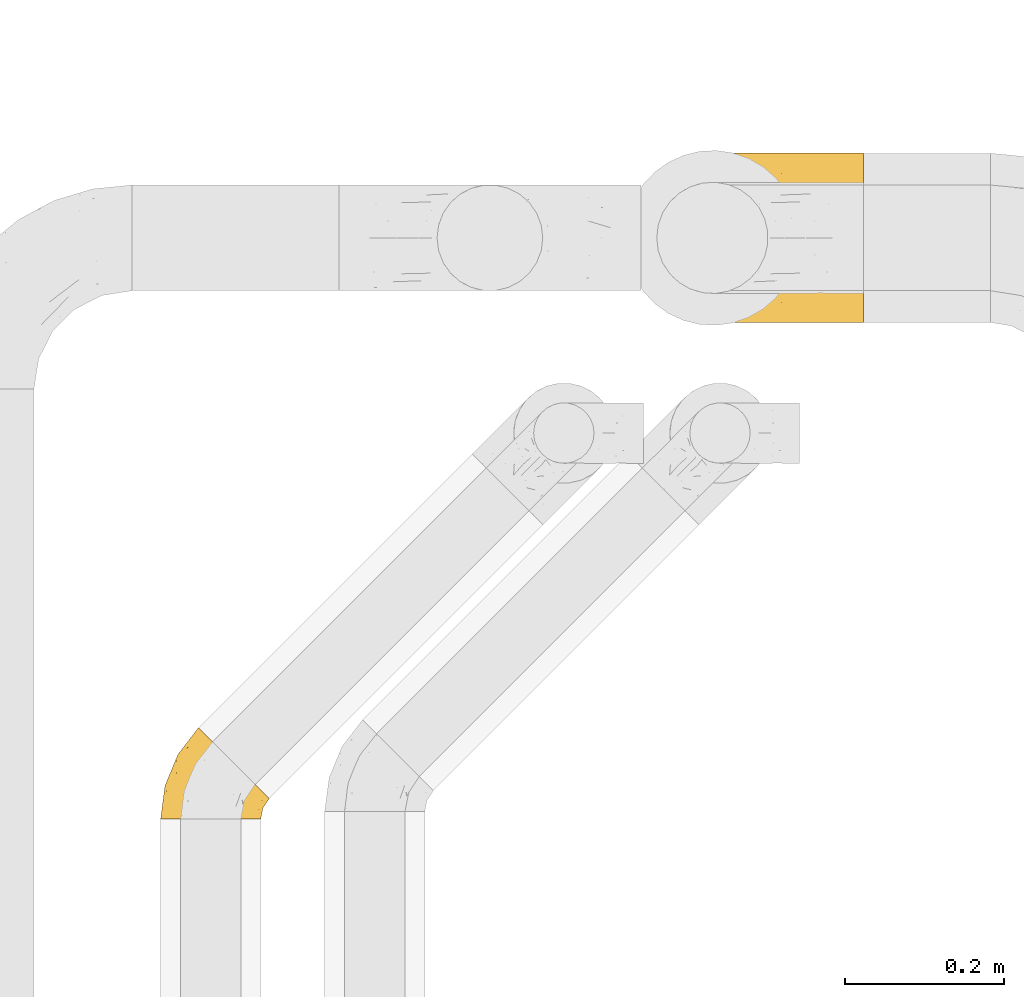
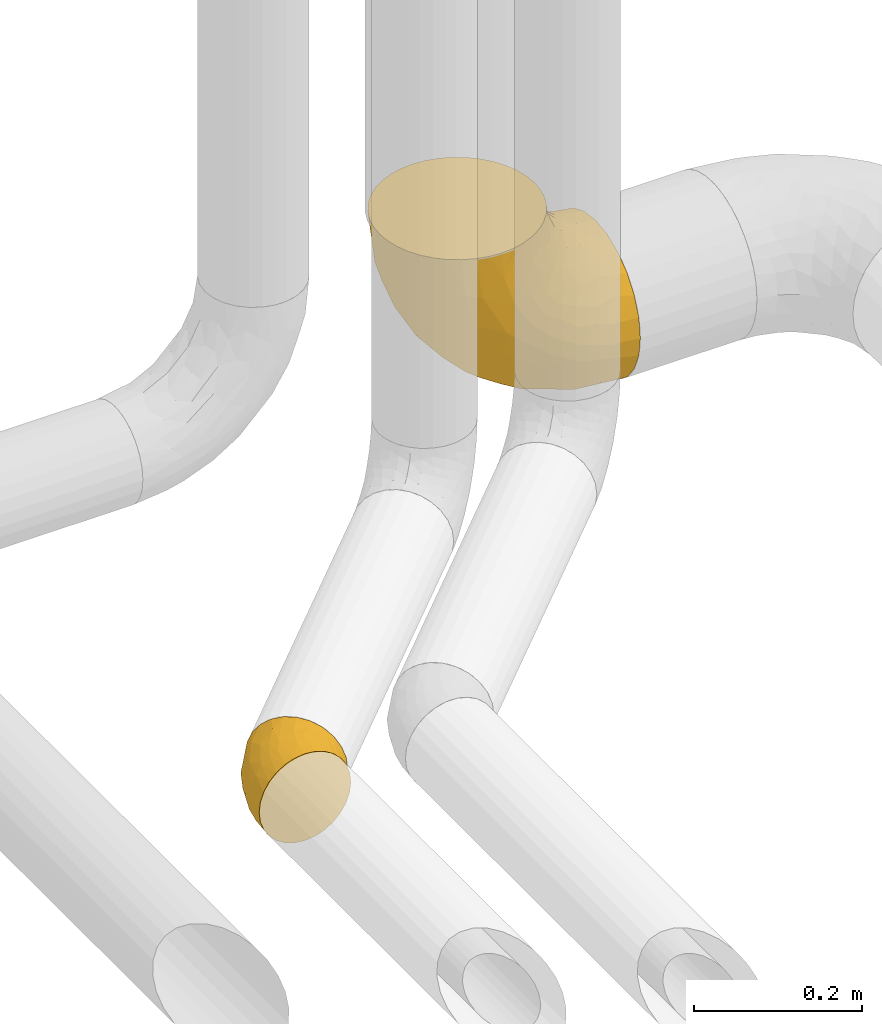
# One storey, part 34 of 93: 2 coverings.
"""IFC2X3 building model written with IfcOpenShell, lengths in millimetres."""

from ifc_helpers import new_model, entity, si_unit, converted_unit, derived_unit, direction, frame, origin, place, context, subcontext, project, spatial, faceted_brep, element, save


model = new_model("IFC2X3")

# Units and contexts
model_context = context("Model", 3, precision=0.01, world=origin(), true_north=direction((6.12303176911189e-17, 1.0)))
body_context = subcontext(model_context, "Body", "Model", "MODEL_VIEW")
ifc_project = project(units=[si_unit("LENGTHUNIT", "METRE", prefix="MILLI"), si_unit("AREAUNIT", "SQUARE_METRE"), si_unit("VOLUMEUNIT", "CUBIC_METRE"), converted_unit("PLANEANGLEUNIT", "DEGREE", entity("IfcRatioMeasure", 0.0174532925199433), si_unit("PLANEANGLEUNIT", "RADIAN"), dimensions=[0, 0, 0, 0, 0, 0, 0]), si_unit("MASSUNIT", "GRAM", prefix="KILO"), derived_unit("MASSDENSITYUNIT", [(si_unit("MASSUNIT", "GRAM", prefix="KILO"), 1), (si_unit("LENGTHUNIT", "METRE"), -3)]), derived_unit("MOMENTOFINERTIAUNIT", [(si_unit("LENGTHUNIT", "METRE"), 4)]), si_unit("TIMEUNIT", "SECOND"), si_unit("FREQUENCYUNIT", "HERTZ"), si_unit("THERMODYNAMICTEMPERATUREUNIT", "DEGREE_CELSIUS"), derived_unit("THERMALTRANSMITTANCEUNIT", [(si_unit("MASSUNIT", "GRAM", prefix="KILO"), 1), (si_unit("THERMODYNAMICTEMPERATUREUNIT", "KELVIN"), -1), (si_unit("TIMEUNIT", "SECOND"), -3)]), derived_unit("VOLUMETRICFLOWRATEUNIT", [(si_unit("LENGTHUNIT", "METRE"), 3), (si_unit("TIMEUNIT", "SECOND"), -1)]), derived_unit("MASSFLOWRATEUNIT", [(si_unit("MASSUNIT", "GRAM", prefix="KILO"), 1), (si_unit("TIMEUNIT", "SECOND"), -1)]), derived_unit("ROTATIONALFREQUENCYUNIT", [(si_unit("TIMEUNIT", "SECOND"), -1)]), si_unit("ELECTRICCURRENTUNIT", "AMPERE"), si_unit("ELECTRICVOLTAGEUNIT", "VOLT"), si_unit("POWERUNIT", "WATT"), si_unit("FORCEUNIT", "NEWTON", prefix="KILO"), si_unit("ILLUMINANCEUNIT", "LUX"), si_unit("LUMINOUSFLUXUNIT", "LUMEN"), si_unit("LUMINOUSINTENSITYUNIT", "CANDELA"), derived_unit("USERDEFINED", [(si_unit("MASSUNIT", "GRAM", prefix="KILO"), -1), (si_unit("LENGTHUNIT", "METRE"), -2), (si_unit("TIMEUNIT", "SECOND"), 3), (si_unit("LUMINOUSFLUXUNIT", "LUMEN"), 1)]), derived_unit("LINEARVELOCITYUNIT", [(si_unit("LENGTHUNIT", "METRE"), 1), (si_unit("TIMEUNIT", "SECOND"), -1)]), si_unit("PRESSUREUNIT", "PASCAL"), derived_unit("USERDEFINED", [(si_unit("LENGTHUNIT", "METRE"), -2), (si_unit("MASSUNIT", "GRAM", prefix="KILO"), 1), (si_unit("TIMEUNIT", "SECOND"), -2)]), derived_unit("LINEARFORCEUNIT", [(si_unit("MASSUNIT", "GRAM", prefix="KILO"), 1), (si_unit("LENGTHUNIT", "METRE"), 1), (si_unit("TIMEUNIT", "SECOND"), -2), (si_unit("LENGTHUNIT", "METRE"), -1)]), derived_unit("PLANARFORCEUNIT", [(si_unit("MASSUNIT", "GRAM", prefix="KILO"), 1), (si_unit("LENGTHUNIT", "METRE"), 1), (si_unit("TIMEUNIT", "SECOND"), -2), (si_unit("LENGTHUNIT", "METRE"), -2)])], contexts=[model_context])

# Site, building, storey
site_placement = place(None, origin())
site = spatial("IfcSite", under=ifc_project, at=site_placement, CompositionType="ELEMENT")
building_placement = place(site_placement, origin())
building = spatial("IfcBuilding", under=site, at=building_placement, CompositionType="ELEMENT")
storey_placement = place(building_placement, frame((0.0, 0.0, -4200.0)))
storey = spatial("IfcBuildingStorey", under=building, at=storey_placement, CompositionType="ELEMENT", Elevation=-4200.0)

# Coverings
covering_1_placement = place(storey_placement, frame((24991.03, 12207.47, 2891.9)))
element("IfcCovering", 1, at=covering_1_placement, inside=storey, Name=":ADSK_", ObjectType=":ADSK_", PredefinedType="INSULATION", context=body_context, shape_type="Brep", body=[
    faceted_brep([(59.74, 202.99, 298.1), (45.49, 194.25, 298.1), (32.79, 183.4, 298.1), (21.93, 170.69, 298.1), (13.2, 156.45, 298.1), (6.81, 141.01, 298.1), (2.91, 124.76, 298.1), (1.6, 108.1, 298.1), (2.91, 91.43, 298.1), (6.81, 75.18, 298.1), (13.21, 59.74, 298.1), (21.94, 45.49, 298.1), (32.79, 32.79, 298.1), (45.5, 21.93, 298.1), (59.74, 13.2, 298.1), (75.18, 6.81, 298.1), (91.43, 2.91, 298.1), (108.1, 1.6, 298.1), (124.76, 2.91, 298.1), (141.01, 6.81, 298.1), (156.45, 13.21, 298.1), (170.7, 21.94, 298.1), (183.4, 32.79, 298.1), (194.26, 45.5, 298.1), (202.99, 59.74, 298.1), (209.38, 75.18, 298.1), (213.28, 91.43, 298.1), (214.6, 108.1, 298.1), (213.28, 124.76, 298.1), (209.38, 141.01, 298.1), (202.99, 156.45, 298.1), (194.25, 170.7, 298.1), (183.4, 183.4, 298.1), (170.69, 194.26, 298.1), (156.45, 202.99, 298.1), (141.01, 209.38, 298.1), (124.76, 213.28, 298.1), (108.1, 214.6, 298.1), (91.43, 213.28, 298.1), (75.18, 209.38, 298.1), (298.1, 108.1, 214.6), (298.1, 80.53, 210.97), (298.1, 54.85, 200.33), (298.1, 32.79, 183.4), (298.1, 15.86, 161.35), (298.1, 5.22, 135.66), (298.1, 4.13, 127.32), (298.1, 1.6, 108.1), (298.1, 5.22, 80.53), (298.1, 15.86, 54.85), (298.1, 32.79, 32.79), (298.1, 54.85, 15.86), (298.1, 80.53, 5.22), (298.1, 108.1, 1.6), (298.1, 135.66, 5.22), (298.1, 161.35, 15.86), (298.1, 183.4, 32.79), (298.1, 200.33, 54.85), (298.1, 210.97, 80.53), (298.1, 214.6, 108.1), (298.1, 212.06, 127.32), (298.1, 210.97, 135.66), (298.1, 200.33, 161.35), (298.1, 183.4, 183.4), (298.1, 161.35, 200.33), (298.1, 135.66, 210.97), (215.9, 136.66, 17.28), (240.25, 108.1, 7.29), (184.63, 108.1, 24.16), (173.62, 212.57, 128.12), (149.55, 214.6, 179.63), (164.59, 214.6, 164.59), (179.63, 214.6, 149.55), (15.37, 125.87, 213.86), (115.17, 147.8, 74.58), (108.31, 127.1, 72.52), (71.9, 138.36, 113.27), (80.69, 201.53, 193.84), (116.68, 201.95, 140.45), (70.43, 181.04, 157.45), (133.37, 108.1, 51.56), (88.44, 108.1, 88.44), (84.59, 209.78, 238.51), (256.47, 190.34, 43.82), (152.12, 132.23, 43.2), (42.47, 157.12, 173.1), (38.05, 134.47, 162.69), (51.56, 108.1, 133.37), (217.02, 212.01, 100.8), (255.82, 214.6, 112.86), (271.69, 214.6, 111.07), (221.39, 203.11, 72.67), (167.38, 206.52, 108.04), (112.86, 214.6, 255.82), (203.39, 187.2, 54.55), (232.94, 169.39, 28.77), (154.06, 185.33, 77.65), (144.28, 196.93, 102.61), (64.22, 202.17, 244.56), (16.68, 145.9, 229.88), (28.56, 167.06, 227.28), (117.19, 210.85, 176.45), (215.66, 214.6, 126.91), (126.91, 214.6, 215.66), (138.23, 214.6, 197.64), (46.68, 184.43, 216.69), (130.52, 169.67, 77.66), (83.03, 164.53, 118.3), (175.16, 173.37, 53.05), (167.12, 155.91, 44.79), (7.29, 108.1, 240.25), (235.74, 214.6, 119.89), (119.89, 214.6, 235.74), (24.16, 108.1, 184.63), (111.07, 214.6, 271.69), (111.97, 185.43, 111.97), (197.64, 214.6, 138.23), (152.84, 212.34, 213.28), (155.48, 205.66, 261.27), (172.59, 202.01, 236.57), (264.78, 211.0, 138.98), (243.36, 171.72, 208.96), (229.26, 159.74, 229.94), (254.06, 147.87, 218.23), (240.21, 210.94, 146.43), (273.24, 198.07, 167.43), (216.52, 183.74, 216.99), (231.35, 190.37, 195.52), (199.76, 172.23, 261.35), (206.05, 155.44, 276.24), (215.74, 204.99, 177.77), (212.96, 212.5, 152.11), (194.42, 211.92, 168.08), (241.64, 203.94, 166.1), (236.85, 133.68, 236.85), (259.64, 182.45, 191.04), (270.63, 161.19, 204.36), (218.68, 108.1, 272.29), (214.32, 137.48, 272.37), (258.6, 126.56, 222.7), (275.05, 137.38, 213.58), (138.58, 212.54, 241.75), (140.53, 210.23, 271.32), (172.52, 194.59, 274.0), (186.21, 185.51, 264.36), (249.02, 108.1, 230.54), (230.54, 108.1, 249.02), (272.29, 108.1, 218.68), (207.91, 174.93, 240.35), (194.73, 189.35, 234.91), (222.52, 141.01, 251.63), (212.36, 158.65, 254.32), (174.06, 207.65, 209.93), (208.29, 197.48, 201.23), (170.15, 212.79, 185.4), (190.86, 207.45, 190.86), (236.85, 82.51, 236.85), (199.76, 43.96, 261.35), (212.36, 57.54, 254.32), (206.05, 60.75, 276.24), (275.05, 78.82, 213.58), (258.6, 89.63, 222.7), (241.64, 12.25, 166.1), (273.24, 18.12, 167.43), (259.64, 33.74, 191.04), (194.73, 26.85, 234.91), (174.06, 8.54, 209.94), (208.28, 18.72, 201.24), (254.06, 68.32, 218.23), (140.54, 5.96, 271.31), (119.89, 1.6, 235.74), (138.59, 3.65, 241.75), (270.58, 54.56, 204.11), (255.82, 1.6, 112.86), (271.69, 1.6, 111.07), (155.48, 10.53, 261.27), (172.52, 21.6, 274.0), (264.78, 5.19, 138.98), (243.36, 44.47, 208.96), (212.94, 3.69, 152.11), (240.19, 5.25, 146.42), (164.59, 1.6, 164.59), (179.63, 1.6, 149.55), (194.44, 4.27, 168.09), (229.26, 56.45, 229.94), (214.32, 78.71, 272.37), (215.75, 11.2, 177.78), (231.35, 25.82, 195.52), (216.52, 32.45, 216.99), (222.52, 75.19, 251.64), (111.07, 1.6, 271.69), (186.21, 30.69, 264.36), (126.91, 1.6, 215.66), (152.84, 3.85, 213.27), (170.15, 3.4, 185.4), (207.92, 41.26, 240.36), (172.6, 14.19, 236.58), (112.86, 1.6, 255.82), (138.23, 1.6, 197.64), (149.55, 1.6, 179.63), (190.86, 8.74, 190.86), (235.74, 1.6, 119.89), (197.64, 1.6, 138.23), (215.66, 1.6, 126.91), (217.02, 4.18, 100.8), (173.62, 3.62, 128.12), (167.38, 9.67, 108.04), (256.48, 25.85, 43.82), (221.39, 13.08, 72.67), (203.39, 29.0, 54.55), (215.9, 79.53, 17.28), (84.59, 6.41, 238.51), (117.19, 5.34, 176.45), (116.68, 14.24, 140.45), (28.56, 49.12, 227.28), (15.37, 90.32, 213.86), (232.94, 46.8, 28.77), (175.16, 42.82, 53.05), (38.83, 86.49, 158.85), (167.12, 60.28, 44.79), (71.9, 77.83, 113.27), (83.03, 51.66, 118.3), (42.47, 59.07, 173.1), (152.13, 83.96, 43.2), (115.17, 68.39, 74.58), (70.43, 35.15, 157.46), (16.68, 70.29, 229.88), (64.22, 14.02, 244.55), (130.52, 46.52, 77.66), (111.97, 30.76, 111.97), (144.28, 19.26, 102.61), (46.69, 31.75, 216.69), (154.06, 30.86, 77.65), (108.31, 89.09, 72.52), (80.7, 14.66, 193.84)], [[[0, 1, 2, 3, 4, 5, 6, 7, 8, 9, 10, 11, 12, 13, 14, 15, 16, 17, 18, 19, 20, 21, 22, 23, 24, 25, 26, 27, 28, 29, 30, 31, 32, 33, 34, 35, 36, 37, 38, 39]], [[40, 41, 42, 43, 44, 45, 46, 47, 48, 49, 50, 51, 52, 53, 54, 55, 56, 57, 58, 59, 60, 61, 62, 63, 64, 65]], [[66, 67, 68]], [[67, 54, 53]], [[69, 70, 71, 72]], [[73, 6, 5]], [[74, 75, 76]], [[77, 78, 79]], [[80, 81, 75]], [[82, 39, 38]], [[83, 57, 56]], [[80, 84, 68]], [[85, 76, 86]], [[76, 81, 87]], [[88, 89, 90, 59]], [[91, 92, 88]], [[93, 82, 38]], [[59, 58, 88]], [[94, 83, 95]], [[91, 58, 57]], [[96, 97, 94]], [[77, 98, 82]], [[66, 55, 54]], [[92, 69, 88]], [[85, 99, 100]], [[101, 78, 77]], [[88, 69, 102]], [[101, 103, 104, 70]], [[39, 98, 0]], [[78, 101, 92]], [[105, 100, 2]], [[55, 95, 56]], [[0, 98, 1]], [[85, 100, 105]], [[5, 4, 99]], [[106, 74, 107]], [[108, 95, 109]], [[99, 73, 5]], [[83, 91, 57]], [[3, 100, 4]], [[66, 95, 55]], [[110, 7, 6]], [[88, 102, 111, 89]], [[58, 91, 88]], [[103, 101, 82]], [[82, 93, 112, 103]], [[113, 110, 73]], [[38, 37, 114, 93]], [[106, 108, 109]], [[86, 113, 73]], [[66, 109, 95]], [[69, 101, 70]], [[107, 76, 85]], [[107, 79, 115]], [[84, 75, 74]], [[98, 39, 82]], [[1, 105, 2]], [[91, 94, 97]], [[54, 67, 66]], [[113, 86, 87]], [[6, 73, 110]], [[101, 77, 82]], [[86, 99, 85]], [[97, 78, 92]], [[79, 78, 115]], [[79, 85, 105]], [[106, 107, 115]], [[85, 79, 107]], [[77, 79, 105]], [[96, 106, 115]], [[74, 106, 109]], [[74, 109, 84]], [[107, 74, 76]], [[109, 66, 84]], [[68, 84, 66]], [[77, 105, 98]], [[1, 98, 105]], [[4, 100, 99]], [[2, 100, 3]], [[101, 69, 92]], [[69, 72, 116, 102]], [[115, 78, 97]], [[108, 96, 94]], [[80, 75, 84]], [[76, 75, 81]], [[96, 108, 106]], [[95, 108, 94]], [[91, 97, 92]], [[115, 97, 96]], [[95, 83, 56]], [[91, 83, 94]], [[87, 86, 76]], [[99, 86, 73]], [[61, 60, 59, 90, 89]], [[117, 118, 119]], [[89, 120, 61]], [[121, 122, 123]], [[120, 124, 125]], [[126, 121, 127]], [[128, 31, 129]], [[130, 131, 132]], [[133, 131, 130]], [[62, 61, 120]], [[122, 134, 123]], [[63, 135, 64]], [[136, 65, 64]], [[63, 62, 125]], [[135, 121, 136]], [[33, 118, 34]], [[28, 137, 138]], [[123, 139, 140]], [[141, 142, 118]], [[65, 140, 40]], [[119, 143, 144]], [[145, 134, 146]], [[145, 147, 139]], [[128, 148, 149]], [[103, 141, 117]], [[138, 150, 151]], [[32, 143, 33]], [[145, 139, 134]], [[35, 34, 142]], [[144, 32, 31]], [[150, 137, 146]], [[37, 36, 114]], [[142, 141, 112]], [[118, 142, 34]], [[122, 151, 150]], [[35, 93, 114]], [[129, 31, 30]], [[118, 33, 143]], [[137, 28, 27]], [[129, 138, 151]], [[35, 114, 36]], [[117, 70, 104, 103]], [[152, 149, 153]], [[138, 129, 29]], [[154, 132, 71]], [[150, 146, 134]], [[63, 125, 135]], [[119, 144, 149]], [[118, 143, 119]], [[29, 28, 138]], [[152, 117, 119]], [[32, 144, 143]], [[153, 126, 127]], [[93, 35, 142]], [[112, 93, 142]], [[118, 117, 141]], [[154, 152, 155]], [[123, 136, 121]], [[148, 122, 126]], [[127, 121, 135]], [[126, 122, 121]], [[136, 123, 140]], [[135, 136, 64]], [[135, 133, 127]], [[153, 130, 155]], [[124, 111, 102]], [[102, 131, 124]], [[147, 40, 140]], [[134, 139, 123]], [[147, 140, 139]], [[136, 140, 65]], [[149, 144, 128]], [[149, 126, 153]], [[141, 103, 112]], [[130, 127, 133]], [[153, 155, 152]], [[127, 130, 153]], [[124, 131, 133]], [[131, 102, 116, 72]], [[130, 132, 155]], [[131, 72, 132]], [[132, 72, 71]], [[154, 71, 70]], [[117, 154, 70]], [[132, 154, 155]], [[117, 152, 154]], [[149, 152, 119]], [[120, 125, 62]], [[135, 125, 133]], [[128, 129, 151]], [[29, 129, 30]], [[128, 151, 148]], [[31, 128, 144]], [[122, 148, 151]], [[126, 149, 148]], [[150, 138, 137]], [[122, 150, 134]], [[125, 124, 133]], [[120, 111, 124]], [[120, 89, 111]], [[145, 146, 156]], [[157, 158, 159]], [[160, 147, 161]], [[162, 163, 164]], [[161, 147, 145]], [[165, 166, 167]], [[168, 161, 156]], [[169, 170, 171]], [[160, 40, 147]], [[164, 43, 42]], [[172, 41, 160]], [[45, 173, 174, 47, 46]], [[21, 175, 176]], [[45, 44, 177]], [[164, 172, 178]], [[179, 180, 162]], [[181, 182, 183]], [[20, 19, 169]], [[44, 43, 163]], [[178, 168, 184]], [[177, 173, 45]], [[137, 26, 185]], [[186, 187, 167]], [[159, 158, 185]], [[165, 167, 188]], [[137, 27, 26]], [[156, 189, 184]], [[18, 17, 190]], [[159, 25, 24]], [[157, 23, 191]], [[176, 22, 21]], [[191, 22, 176]], [[162, 186, 179]], [[171, 192, 193]], [[22, 191, 23]], [[189, 137, 185]], [[193, 194, 166]], [[175, 169, 171]], [[165, 195, 157]], [[176, 196, 191]], [[184, 168, 156]], [[169, 175, 20]], [[165, 191, 196]], [[190, 197, 19]], [[175, 171, 193]], [[185, 158, 189]], [[18, 190, 19]], [[187, 164, 178]], [[175, 21, 20]], [[146, 137, 189]], [[25, 185, 26]], [[19, 197, 169]], [[196, 176, 175]], [[193, 192, 198, 199]], [[194, 183, 200]], [[175, 193, 196]], [[195, 184, 158]], [[164, 42, 172]], [[184, 188, 178]], [[187, 178, 188]], [[41, 172, 42]], [[168, 178, 172]], [[167, 187, 188]], [[162, 164, 187]], [[177, 44, 163]], [[180, 201, 177]], [[156, 161, 145]], [[160, 161, 168]], [[172, 160, 168]], [[160, 41, 40]], [[165, 196, 166]], [[157, 195, 158]], [[170, 169, 197]], [[170, 192, 171]], [[186, 167, 200]], [[186, 183, 179]], [[187, 186, 162]], [[183, 186, 200]], [[179, 182, 202, 203]], [[181, 183, 194]], [[182, 179, 183]], [[181, 194, 199]], [[166, 194, 200]], [[193, 199, 194]], [[166, 200, 167]], [[193, 166, 196]], [[164, 163, 43]], [[163, 162, 180]], [[25, 159, 185]], [[159, 24, 23]], [[23, 157, 159]], [[165, 157, 191]], [[165, 188, 195]], [[184, 195, 188]], [[184, 189, 158]], [[146, 189, 156]], [[203, 180, 179]], [[163, 180, 177]], [[201, 180, 203]], [[201, 173, 177]], [[204, 205, 206]], [[207, 208, 209]], [[51, 210, 52]], [[204, 47, 174, 173]], [[205, 203, 202, 182]], [[68, 67, 210]], [[211, 192, 170, 197]], [[206, 212, 213]], [[214, 12, 11]], [[199, 212, 205]], [[215, 9, 8]], [[204, 208, 48]], [[216, 210, 51]], [[217, 216, 209]], [[67, 53, 52]], [[87, 218, 113]], [[50, 49, 207]], [[210, 216, 219]], [[218, 87, 220]], [[220, 221, 222]], [[50, 207, 216]], [[223, 219, 224]], [[212, 199, 198, 192]], [[68, 210, 223]], [[50, 216, 51]], [[222, 221, 225]], [[16, 211, 197]], [[48, 208, 49]], [[16, 197, 190, 17]], [[226, 10, 9]], [[227, 15, 14]], [[16, 15, 211]], [[221, 228, 229]], [[230, 206, 213]], [[13, 12, 231]], [[228, 232, 229]], [[226, 222, 214]], [[211, 212, 192]], [[208, 204, 206]], [[231, 227, 13]], [[80, 223, 233]], [[222, 226, 218]], [[81, 220, 87]], [[214, 10, 226]], [[233, 223, 224]], [[226, 215, 218]], [[225, 234, 231]], [[204, 173, 201, 203]], [[215, 8, 110]], [[208, 206, 230]], [[7, 110, 8]], [[213, 212, 234]], [[212, 206, 205]], [[231, 214, 222]], [[47, 204, 48]], [[234, 211, 227]], [[234, 212, 211]], [[227, 211, 15]], [[67, 52, 210]], [[113, 215, 110]], [[215, 226, 9]], [[225, 213, 234]], [[230, 229, 232]], [[228, 224, 219]], [[225, 221, 229]], [[224, 221, 220]], [[217, 228, 219]], [[221, 224, 228]], [[220, 81, 233]], [[68, 223, 80]], [[210, 219, 223]], [[225, 229, 213]], [[222, 225, 231]], [[13, 227, 14]], [[231, 234, 227]], [[12, 214, 231]], [[10, 214, 11]], [[203, 205, 204]], [[205, 182, 181, 199]], [[217, 232, 228]], [[209, 208, 230]], [[220, 233, 224]], [[80, 233, 81]], [[216, 217, 219]], [[232, 217, 209]], [[229, 230, 213]], [[230, 232, 209]], [[208, 207, 49]], [[216, 207, 209]], [[222, 218, 220]], [[113, 218, 215]]]),
])
covering_2_placement = place(storey_placement, frame((24403.45, 11582.72, 2935.4)))
element("IfcCovering", 2, at=covering_2_placement, inside=storey, Name=":ADSK_", ObjectType=":ADSK_", PredefinedType="INSULATION", context=body_context, shape_type="Brep", body=[
    faceted_brep([(127.6, 1.6, 64.6), (126.02, 1.6, 78.61), (121.36, 1.6, 91.93), (113.85, 1.6, 103.87), (103.88, 1.6, 113.85), (91.93, 1.6, 121.35), (78.62, 1.6, 126.01), (64.6, 1.6, 127.6), (50.58, 1.6, 126.02), (37.26, 1.6, 121.36), (25.32, 1.6, 113.85), (15.34, 1.6, 103.88), (7.84, 1.6, 91.93), (3.18, 1.6, 78.62), (1.6, 1.6, 64.6), (3.17, 1.6, 50.58), (7.83, 1.6, 37.26), (15.34, 1.6, 25.32), (25.31, 1.6, 15.34), (37.26, 1.6, 7.84), (50.57, 1.6, 3.18), (64.6, 1.6, 1.6), (78.61, 1.6, 3.17), (91.93, 1.6, 7.83), (103.87, 1.6, 15.34), (113.85, 1.6, 25.31), (121.35, 1.6, 37.26), (126.01, 1.6, 50.57), (116.16, 50.03, 10.04), (105.41, 60.78, 3.74), (93.88, 72.31, 1.6), (82.35, 83.84, 3.74), (71.61, 94.58, 10.04), (62.38, 103.81, 20.05), (55.31, 110.89, 33.1), (50.85, 115.34, 48.29), (49.34, 116.85, 64.6), (50.85, 115.34, 80.9), (55.31, 110.89, 96.1), (62.38, 103.81, 109.14), (71.61, 94.58, 119.15), (82.35, 83.84, 125.45), (93.88, 72.31, 127.6), (105.41, 60.78, 125.45), (116.16, 50.03, 119.15), (120.77, 45.42, 114.15), (125.38, 40.81, 109.14), (132.46, 33.73, 96.1), (136.91, 29.28, 80.9), (138.43, 27.76, 64.6), (136.91, 29.28, 48.29), (132.46, 33.73, 33.1), (125.38, 40.81, 20.05), (120.77, 45.42, 15.04), (22.6, 33.82, 108.06), (23.43, 83.1, 64.6), (39.51, 85.62, 102.01), (7.15, 43.78, 64.6), (21.33, 74.5, 81.29), (54.41, 47.23, 124.58), (42.67, 26.33, 122.68), (60.82, 72.24, 122.19), (8.89, 37.3, 84.57), (37.93, 62.02, 112.99), (77.99, 51.6, 127.6), (85.47, 61.34, 127.6), (13.21, 29.09, 97.28), (21.55, 59.83, 96.29), (32.6, 29.32, 117.06), (35.12, 91.1, 90.56), (66.4, 15.3, 127.6), (68.0, 27.48, 127.6), (73.0, 39.54, 127.6), (44.38, 52.36, 119.72), (108.74, 40.86, 119.02), (96.7, 47.06, 124.88), (111.89, 30.85, 113.49), (94.64, 27.4, 122.23), (95.49, 13.62, 120.07), (107.76, 15.33, 111.97), (118.96, 19.92, 101.82), (117.56, 9.76, 99.77), (132.32, 21.41, 75.01), (125.3, 14.35, 87.5), (127.95, 11.58, 75.66), (129.01, 24.77, 90.26), (81.37, 29.18, 126.38), (81.14, 15.88, 125.7), (85.44, 40.48, 126.48), (130.41, 15.75, 64.6), (122.25, 30.66, 104.64), (125.3, 14.35, 41.69), (107.76, 15.33, 17.22), (130.99, 19.96, 51.88), (108.74, 40.86, 10.17), (127.14, 24.41, 36.0), (118.96, 19.92, 27.36), (96.7, 47.06, 4.31), (85.47, 61.34, 1.6), (94.64, 27.4, 6.96), (86.43, 38.13, 3.11), (117.56, 9.76, 29.41), (81.13, 15.88, 3.49), (82.94, 27.28, 3.26), (95.48, 13.62, 9.12), (111.89, 30.85, 15.69), (127.93, 10.6, 54.84), (73.0, 39.54, 1.6), (77.99, 51.6, 1.6), (68.0, 27.48, 1.6), (66.4, 15.3, 1.6), (122.33, 31.09, 24.34), (54.41, 47.23, 4.61), (60.82, 72.24, 7.0), (22.59, 33.82, 21.14), (37.93, 62.01, 16.2), (32.6, 29.32, 12.13), (13.21, 29.09, 31.92), (21.55, 59.83, 32.9), (39.5, 85.61, 27.18), (35.12, 91.1, 38.63), (8.88, 37.3, 44.63), (21.32, 74.49, 47.91), (42.67, 26.33, 6.52), (44.38, 52.36, 9.47)], [[[0, 1, 2, 3, 4, 5, 6, 7, 8, 9, 10, 11, 12, 13, 14, 15, 16, 17, 18, 19, 20, 21, 22, 23, 24, 25, 26, 27]], [[28, 29, 30, 31, 32, 33, 34, 35, 36, 37, 38, 39, 40, 41, 42, 43, 44, 45, 46, 47, 48, 49, 50, 51, 52, 53]], [[54, 11, 10]], [[37, 36, 55]], [[38, 56, 39]], [[55, 57, 58]], [[8, 59, 60]], [[41, 61, 59]], [[57, 13, 62]], [[63, 40, 39]], [[41, 64, 65, 42]], [[64, 41, 59]], [[61, 41, 40]], [[66, 54, 67]], [[56, 63, 39]], [[63, 67, 54]], [[62, 58, 57]], [[62, 67, 58]], [[54, 10, 68]], [[66, 12, 11]], [[66, 62, 12]], [[13, 57, 14]], [[63, 56, 67]], [[69, 56, 38]], [[37, 58, 69]], [[63, 54, 68]], [[68, 10, 9]], [[8, 7, 70, 71]], [[59, 71, 72, 64]], [[59, 8, 71]], [[62, 66, 67]], [[54, 66, 11]], [[73, 59, 61]], [[37, 55, 58]], [[60, 68, 9]], [[62, 13, 12]], [[37, 69, 38]], [[67, 56, 69]], [[67, 69, 58]], [[8, 60, 9]], [[73, 60, 59]], [[40, 63, 61]], [[73, 61, 63]], [[63, 68, 73]], [[60, 73, 68]], [[46, 45, 44, 74]], [[64, 75, 65]], [[76, 74, 77]], [[65, 75, 43]], [[44, 75, 74]], [[78, 79, 77]], [[80, 76, 79]], [[81, 3, 2]], [[82, 49, 48]], [[83, 84, 82]], [[77, 79, 76]], [[75, 44, 43]], [[83, 85, 80]], [[47, 85, 48]], [[86, 87, 77]], [[79, 78, 4]], [[5, 4, 78]], [[87, 6, 5]], [[78, 87, 5]], [[87, 70, 6]], [[72, 86, 88]], [[43, 42, 65]], [[81, 79, 3]], [[89, 84, 0]], [[84, 83, 1]], [[1, 83, 2]], [[3, 79, 4]], [[76, 90, 46]], [[83, 80, 81]], [[80, 90, 76]], [[70, 87, 71]], [[88, 64, 72]], [[70, 7, 6]], [[87, 78, 77]], [[87, 86, 71]], [[83, 81, 2]], [[79, 81, 80]], [[0, 84, 1]], [[82, 84, 89]], [[49, 82, 89]], [[82, 48, 85]], [[85, 47, 90]], [[82, 85, 83]], [[85, 90, 80]], [[46, 90, 47]], [[74, 76, 46]], [[77, 74, 75]], [[88, 77, 75]], [[71, 86, 72]], [[77, 88, 86]], [[64, 88, 75]], [[27, 26, 91]], [[25, 24, 92]], [[89, 93, 49]], [[28, 53, 52, 94]], [[95, 91, 96]], [[95, 50, 93]], [[97, 98, 29]], [[97, 99, 100]], [[92, 101, 25]], [[102, 103, 104]], [[92, 105, 96]], [[97, 29, 28]], [[104, 92, 24]], [[92, 99, 105]], [[106, 91, 93]], [[99, 103, 100]], [[26, 101, 91]], [[100, 103, 107]], [[92, 96, 101]], [[52, 105, 94]], [[101, 26, 25]], [[23, 22, 102]], [[104, 24, 23]], [[91, 95, 93]], [[97, 100, 108]], [[109, 102, 110]], [[102, 22, 110]], [[99, 94, 105]], [[52, 51, 111]], [[92, 104, 99]], [[106, 0, 27]], [[22, 21, 110]], [[102, 104, 23]], [[98, 97, 108]], [[98, 30, 29]], [[91, 101, 96]], [[111, 95, 96]], [[50, 95, 51]], [[49, 93, 50]], [[106, 93, 89]], [[0, 106, 89]], [[91, 106, 27]], [[95, 111, 51]], [[96, 105, 111]], [[105, 52, 111]], [[99, 97, 94]], [[97, 28, 94]], [[99, 104, 103]], [[108, 100, 107]], [[102, 109, 103]], [[107, 103, 109]], [[31, 112, 113]], [[114, 115, 116]], [[31, 30, 98, 108]], [[114, 116, 18]], [[114, 117, 118]], [[119, 115, 118]], [[36, 35, 55]], [[118, 120, 119]], [[121, 122, 118]], [[115, 119, 33]], [[32, 115, 33]], [[34, 119, 120]], [[120, 118, 122]], [[19, 123, 20]], [[112, 108, 107, 109]], [[124, 115, 113]], [[20, 109, 110, 21]], [[33, 119, 34]], [[114, 18, 17]], [[55, 35, 122]], [[118, 115, 114]], [[112, 31, 108]], [[120, 35, 34]], [[116, 19, 18]], [[122, 121, 57]], [[117, 17, 16]], [[15, 14, 57]], [[15, 57, 121]], [[123, 19, 116]], [[117, 121, 118]], [[122, 57, 55]], [[15, 121, 16]], [[117, 114, 17]], [[20, 112, 109]], [[121, 117, 16]], [[31, 113, 32]], [[35, 120, 122]], [[124, 123, 116]], [[20, 123, 112]], [[124, 113, 112]], [[115, 32, 113]], [[123, 124, 112]], [[116, 115, 124]]]),
])

save(model, "model.ifc")
